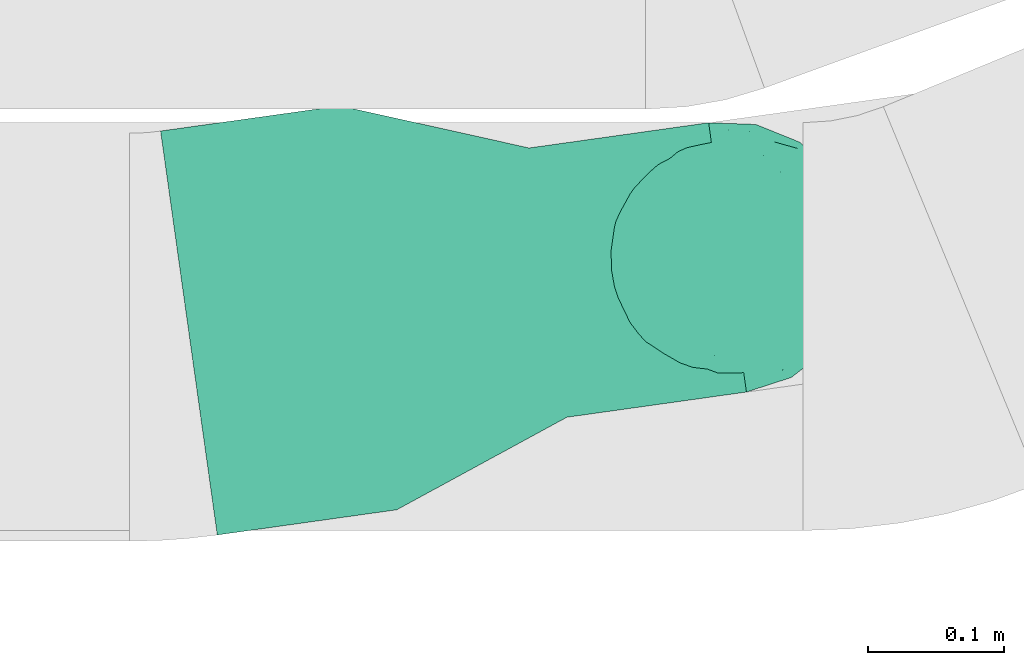
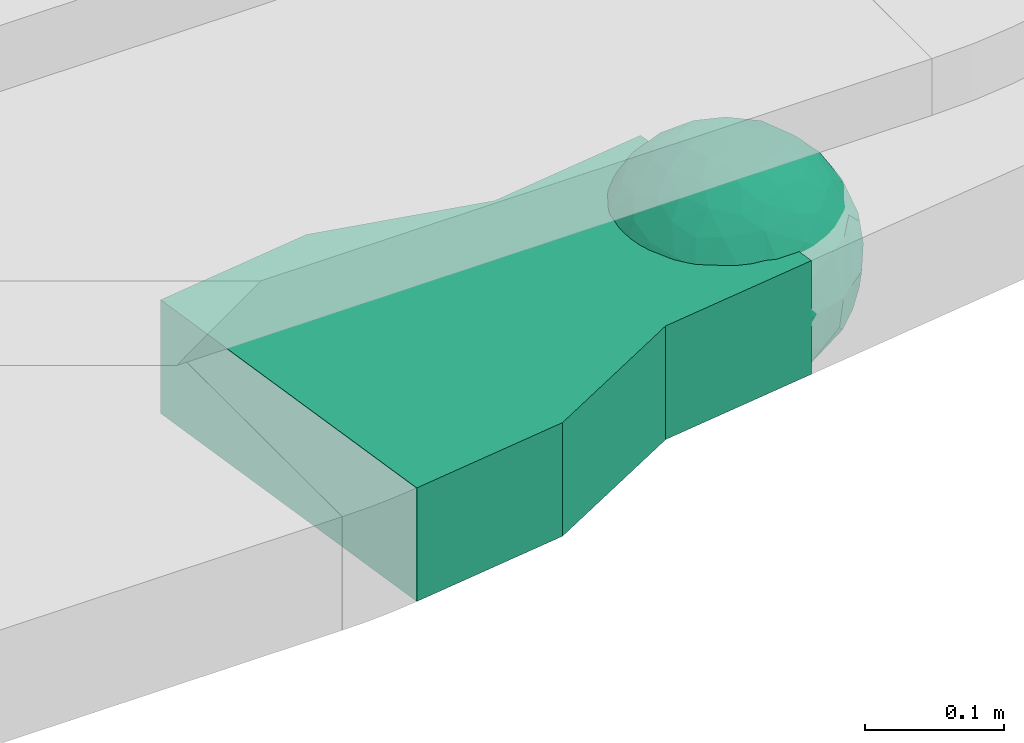
# One storey, part 30 of 32: 1 flow fitting.
"""IFC2X3 building model written with IfcOpenShell, lengths in millimetres."""

from ifc_helpers import new_model, entity, si_unit, converted_unit, derived_unit, direction, frame, origin, place, context, subcontext, project, spatial, faceted_brep, source, transform, mapped, material, material_list, type_object, type_shapes, element, save


model = new_model("IFC2X3")

# Units and contexts
model_context = context("Model", 3, precision=0.01, world=origin(), true_north=direction((6.12303176911189e-17, 1.0)))
body_context = subcontext(model_context, "Body", "Model", "MODEL_VIEW")
ifc_project = project(units=[si_unit("LENGTHUNIT", "METRE", prefix="MILLI"), si_unit("AREAUNIT", "SQUARE_METRE"), si_unit("VOLUMEUNIT", "CUBIC_METRE"), converted_unit("PLANEANGLEUNIT", "DEGREE", entity("IfcRatioMeasure", 0.0174532925199433), si_unit("PLANEANGLEUNIT", "RADIAN"), dimensions=[0, 0, 0, 0, 0, 0, 0]), si_unit("MASSUNIT", "GRAM", prefix="KILO"), derived_unit("MASSDENSITYUNIT", [(si_unit("MASSUNIT", "GRAM", prefix="KILO"), 1), (si_unit("LENGTHUNIT", "METRE"), -3)]), derived_unit("MOMENTOFINERTIAUNIT", [(si_unit("LENGTHUNIT", "METRE"), 4)]), si_unit("TIMEUNIT", "SECOND"), si_unit("FREQUENCYUNIT", "HERTZ"), si_unit("THERMODYNAMICTEMPERATUREUNIT", "DEGREE_CELSIUS"), derived_unit("THERMALTRANSMITTANCEUNIT", [(si_unit("MASSUNIT", "GRAM", prefix="KILO"), 1), (si_unit("THERMODYNAMICTEMPERATUREUNIT", "KELVIN"), -1), (si_unit("TIMEUNIT", "SECOND"), -3)]), derived_unit("VOLUMETRICFLOWRATEUNIT", [(si_unit("LENGTHUNIT", "METRE"), 3), (si_unit("TIMEUNIT", "SECOND"), -1)]), derived_unit("MASSFLOWRATEUNIT", [(si_unit("MASSUNIT", "GRAM", prefix="KILO"), 1), (si_unit("TIMEUNIT", "SECOND"), -1)]), derived_unit("ROTATIONALFREQUENCYUNIT", [(si_unit("TIMEUNIT", "SECOND"), -1)]), si_unit("ELECTRICCURRENTUNIT", "AMPERE"), si_unit("ELECTRICVOLTAGEUNIT", "VOLT"), si_unit("POWERUNIT", "WATT"), si_unit("FORCEUNIT", "NEWTON", prefix="KILO"), si_unit("ILLUMINANCEUNIT", "LUX"), si_unit("LUMINOUSFLUXUNIT", "LUMEN"), si_unit("LUMINOUSINTENSITYUNIT", "CANDELA"), derived_unit("USERDEFINED", [(si_unit("MASSUNIT", "GRAM", prefix="KILO"), -1), (si_unit("LENGTHUNIT", "METRE"), -2), (si_unit("TIMEUNIT", "SECOND"), 3), (si_unit("LUMINOUSFLUXUNIT", "LUMEN"), 1)]), derived_unit("LINEARVELOCITYUNIT", [(si_unit("LENGTHUNIT", "METRE"), 1), (si_unit("TIMEUNIT", "SECOND"), -1)]), si_unit("PRESSUREUNIT", "PASCAL"), derived_unit("USERDEFINED", [(si_unit("LENGTHUNIT", "METRE"), -2), (si_unit("MASSUNIT", "GRAM", prefix="KILO"), 1), (si_unit("TIMEUNIT", "SECOND"), -2)]), derived_unit("LINEARFORCEUNIT", [(si_unit("MASSUNIT", "GRAM", prefix="KILO"), 1), (si_unit("LENGTHUNIT", "METRE"), 1), (si_unit("TIMEUNIT", "SECOND"), -2), (si_unit("LENGTHUNIT", "METRE"), -1)]), derived_unit("PLANARFORCEUNIT", [(si_unit("MASSUNIT", "GRAM", prefix="KILO"), 1), (si_unit("LENGTHUNIT", "METRE"), 1), (si_unit("TIMEUNIT", "SECOND"), -2), (si_unit("LENGTHUNIT", "METRE"), -2)])], contexts=[model_context])

# Site, building, storey
site_placement = place(None, origin())
site = spatial("IfcSite", under=ifc_project, at=site_placement, CompositionType="ELEMENT")
building_placement = place(site_placement, origin())
building = spatial("IfcBuilding", under=site, at=building_placement, CompositionType="ELEMENT")
storey_placement = place(building_placement, frame((0.0, 0.0, 8100.0)))
storey = spatial("IfcBuildingStorey", under=building, at=storey_placement, CompositionType="ELEMENT", Elevation=8100.0)

# Flow fitting
ifc_material_1 = material()
ifc_material_2 = material()
ifc_material_list = material_list([ifc_material_1, ifc_material_2])
cable_carrier_fitting_type = type_object("IfcCableCarrierFittingType", Name="470_DKC_G5_Sheet reducer:-", PredefinedType="NOTDEFINED", material=ifc_material_1)
shared_shape = source(origin(), body_context, "Body", "Brep", [
    faceted_brep([(76.48, -37.8, -52.17), (89.29, -26.17, -36.65), (85.27, -46.63, -23.54), (-17.29, -34.78, -92.15), (0.0, -44.16, -89.72), (-24.64, -51.58, -82.05), (76.33, -15.08, -62.82), (55.58, -29.55, -77.71), (-17.1, 96.98, 0.0), (-18.67, 88.89, -41.84), (-33.9, 89.53, -28.9), (-45.46, -10.48, -88.45), (-19.82, 5.04, -97.89), (-23.66, -16.13, -95.81), (92.54, 33.68, 0.0), (85.28, 45.77, -25.16), (86.6, 50.0, 0.0), (49.24, -85.29, 0.0), (62.2, -72.19, -30.32), (64.28, -76.6, 0.0), (97.17, -8.72, -21.95), (90.76, 0.0, -41.98), (96.14, 14.4, -23.44), (98.48, 17.36, 0.0), (98.48, 0.0, 0.0), (79.01, 8.48, -60.71), (76.48, 37.8, -52.17), (87.7, 23.44, -41.95), (29.16, -37.6, -87.95), (20.3, -63.77, -74.31), (-69.62, 53.19, -48.2), (-47.21, 56.75, -67.46), (-61.6, 43.47, -65.69), (29.45, 71.32, -63.61), (47.21, 56.75, -67.46), (30.04, 49.65, -81.44), (-49.67, -77.09, -39.87), (-34.2, -93.97, 0.0), (-49.24, -85.29, 0.0), (61.4, 65.14, -44.57), (74.68, 59.14, -30.41), (61.95, 44.54, -64.64), (28.77, -89.42, -34.29), (34.2, -93.97, 0.0), (25.65, -95.48, 0.0), (17.1, -96.98, 0.0), (-64.28, -76.6, 0.0), (-75.44, -63.3, 0.0), (-74.75, -61.55, -24.99), (7.5, -83.69, -54.22), (36.49, -70.37, -60.97), (-76.48, -37.8, -52.17), (-87.07, -22.49, -43.74), (-79.06, -6.54, -60.88), (63.53, 0.0, -77.22), (-63.53, 0.0, -77.22), (-81.93, 16.04, -55.05), (-98.48, -17.36, 0.0), (-95.57, -17.05, -24.0), (-92.54, -33.68, 0.0), (65.86, 23.41, -71.51), (-19.3, 70.27, -68.49), (-44.33, 79.42, -41.56), (-76.48, 37.8, -52.17), (-45.05, 37.36, -81.09), (-67.2, 22.41, -70.59), (45.89, 15.54, -87.48), (-67.14, -22.46, -70.63), (-97.69, 5.09, -20.78), (-90.76, 0.0, -41.98), (-92.54, 33.68, 0.0), (-92.15, 27.2, -27.72), (28.87, 87.52, -38.83), (7.5, 83.69, -54.22), (1.23, 95.73, -28.9), (3.52, -95.84, -28.34), (-8.55, -98.49, 0.0), (-12.28, -96.15, -24.6), (75.44, 63.3, 0.0), (64.28, 76.6, 0.0), (75.44, -63.3, 0.0), (86.6, -50.0, 0.0), (-75.44, 63.3, 0.0), (-84.89, 46.81, -24.54), (-86.6, 50.0, 0.0), (-65.62, -61.39, -43.88), (-47.21, -56.75, -67.46), (-85.24, -44.68, -27.17), (46.02, 37.17, -80.63), (-63.18, 67.68, -37.79), (-7.15, -67.62, -73.33), (31.54, -5.3, -94.75), (9.85, -20.5, -97.38), (0.0, 13.3, -99.11), (49.35, -11.18, -86.25), (92.54, -33.68, 0.0), (98.48, -17.36, 0.0), (49.24, 85.29, 0.0), (46.4, 79.11, -39.86), (34.2, 93.97, 0.0), (-53.11, 15.12, -83.37), (64.53, -54.17, -53.86), (47.21, -56.75, -67.46), (22.89, 27.57, -93.36), (74.68, -59.14, -30.41), (46.4, -79.11, -39.86), (-15.74, 23.19, -95.99), (2.81, 33.98, -94.01), (9.21, 52.39, -84.68), (9.73, 69.75, -71.0), (17.1, 96.98, 0.0), (-5.62, -90.16, -42.88), (0.0, -100.0, 0.0), (-25.13, -93.37, -25.51), (-25.95, -84.88, -46.06), (-17.1, -96.98, 0.0), (-10.24, -80.78, -58.05), (-31.24, -69.76, -64.48), (-42.19, -33.64, -84.2), (-35.78, 18.55, -91.52), (-61.62, -43.52, -65.64), (-17.34, 40.89, -89.6), (-29.1, 55.69, -77.79), (-10.66, 57.03, -81.45), (-59.77, -75.57, -26.75), (-86.6, -50.0, 0.0), (-98.48, 0.0, 0.0), (-98.48, 17.36, 0.0), (-74.77, 60.7, -26.92), (-64.28, 76.6, 0.0), (-49.24, 85.29, 0.0), (-34.2, 93.97, 0.0), (0.0, 100.0, 0.0), (-76.48, -37.8, 52.17), (-89.29, -26.17, 36.65), (-85.27, -46.63, 23.54), (17.29, -34.78, 92.15), (0.0, -44.16, 89.72), (24.64, -51.58, 82.05), (-76.33, -15.08, 62.82), (-55.58, -29.55, 77.71), (18.67, 88.89, 41.84), (33.9, 89.53, 28.9), (17.34, 40.89, 89.6), (15.74, 23.19, 95.99), (35.78, 18.55, 91.52), (-85.28, 45.77, 25.16), (-62.2, -72.19, 30.32), (-97.17, -8.72, 21.95), (-96.14, 14.4, 23.44), (-79.01, 8.48, 60.71), (-76.48, 37.8, 52.17), (-87.7, 23.44, 41.95), (-29.16, -37.6, 87.95), (-20.3, -63.77, 74.31), (69.62, 53.19, 48.2), (47.21, 56.75, 67.46), (61.6, 43.47, 65.69), (-61.4, 65.14, 44.57), (49.27, -77.35, 39.88), (-74.68, 59.14, 30.41), (-61.95, 44.54, 64.64), (-7.5, -83.69, 54.22), (-36.49, -70.37, 60.97), (-28.77, -89.42, 34.29), (74.74, -61.65, 24.74), (3.0, -95.52, 29.45), (-13.47, -92.75, 34.88), (76.48, -37.8, 52.17), (87.07, -22.49, 43.74), (79.06, -6.54, 60.88), (-63.53, 0.0, 77.22), (63.53, 0.0, 77.22), (81.93, 16.04, 55.05), (95.57, -17.05, 24.0), (-65.86, 23.41, 71.51), (19.3, 70.27, 68.49), (44.33, 79.42, 41.56), (76.48, 37.8, 52.17), (45.05, 37.36, 81.09), (67.2, 22.41, 70.59), (-45.89, 15.54, 87.48), (67.14, -22.46, 70.63), (97.69, 5.09, 20.78), (90.76, 0.0, 41.98), (92.15, 27.2, 27.72), (-28.87, 87.52, 38.83), (-7.5, 83.69, 54.22), (-1.23, 95.73, 28.9), (7.15, -67.62, 73.33), (30.04, -71.02, 63.66), (-90.76, 0.0, 41.98), (84.89, 46.81, 24.54), (65.66, -61.85, 43.17), (47.21, -56.75, 67.46), (85.24, -44.68, 27.17), (-30.04, 49.65, 81.44), (-47.21, 56.75, 67.46), (-46.02, 37.17, 80.63), (63.18, 67.68, 37.79), (-31.54, -5.3, 94.75), (-9.85, -20.5, 97.38), (0.0, 13.3, 99.11), (-49.35, -11.18, 86.25), (-46.4, 79.11, 39.86), (-29.45, 71.32, 63.61), (24.31, -93.79, 24.74), (-64.53, -54.17, 53.86), (-47.21, -56.75, 67.46), (-22.89, 27.57, 93.36), (-46.4, -79.11, 39.86), (-74.68, -59.14, 30.41), (19.82, 5.04, 97.89), (-2.81, 33.98, 94.01), (-9.21, 52.39, 84.68), (-9.73, 69.75, 71.0), (9.65, -80.54, 58.49), (23.47, -86.31, 44.72), (35.11, -89.62, 27.11), (42.19, -33.64, 84.2), (23.66, -16.13, 95.81), (45.46, -10.48, 88.45), (61.62, -43.52, 65.64), (29.1, 55.69, 77.79), (10.66, 57.03, 81.45), (59.35, -75.82, 26.99), (74.77, 60.7, 26.92), (53.11, 15.12, 83.37)], [[[0, 1, 2]], [[3, 4, 5]], [[6, 0, 7]], [[8, 9, 10]], [[11, 12, 13]], [[14, 15, 16]], [[17, 18, 19]], [[20, 21, 22]], [[22, 23, 24]], [[25, 26, 27]], [[4, 28, 29]], [[30, 31, 32]], [[33, 34, 35]], [[36, 37, 38]], [[39, 40, 41]], [[42, 43, 44, 45]], [[46, 47, 48]], [[49, 50, 42]], [[51, 52, 53]], [[54, 25, 6]], [[55, 53, 56]], [[57, 58, 59]], [[26, 25, 60]], [[61, 31, 62]], [[32, 63, 30]], [[64, 65, 32]], [[54, 66, 60]], [[53, 67, 51]], [[58, 68, 69]], [[68, 70, 71]], [[72, 73, 74]], [[75, 76, 77]], [[6, 7, 54]], [[24, 20, 22]], [[78, 40, 79]], [[15, 26, 40]], [[1, 21, 20]], [[80, 2, 81]], [[63, 56, 71]], [[82, 83, 84]], [[36, 85, 86]], [[87, 58, 52]], [[35, 34, 88]], [[62, 31, 89]], [[42, 75, 49]], [[4, 29, 90]], [[91, 92, 93]], [[7, 94, 54]], [[6, 1, 0]], [[95, 81, 2]], [[24, 96, 20]], [[1, 20, 95]], [[1, 95, 2]], [[27, 22, 21]], [[15, 14, 22]], [[25, 27, 21]], [[15, 78, 16]], [[41, 40, 26]], [[40, 78, 15]], [[39, 97, 79]], [[97, 98, 99]], [[40, 39, 79]], [[33, 73, 72]], [[21, 1, 6]], [[25, 54, 60]], [[64, 100, 65]], [[26, 15, 27]], [[6, 25, 21]], [[0, 101, 7]], [[102, 28, 7]], [[92, 91, 28]], [[94, 28, 91]], [[88, 34, 41]], [[54, 94, 66]], [[41, 26, 60]], [[103, 91, 93]], [[88, 41, 60]], [[20, 96, 95]], [[101, 18, 102]], [[104, 80, 19]], [[101, 0, 104]], [[18, 105, 102]], [[43, 42, 105]], [[17, 43, 105]], [[29, 28, 102]], [[28, 4, 92]], [[105, 50, 102]], [[90, 29, 49]], [[88, 60, 66]], [[41, 34, 39]], [[34, 98, 39]], [[97, 39, 98]], [[103, 66, 91]], [[88, 66, 103]], [[12, 106, 93]], [[33, 98, 34]], [[107, 103, 93]], [[35, 103, 108]], [[103, 35, 88]], [[33, 109, 73]], [[109, 35, 108]], [[110, 72, 74]], [[72, 110, 99]], [[98, 33, 72]], [[99, 98, 72]], [[80, 104, 2]], [[0, 2, 104]], [[101, 104, 18]], [[7, 101, 102]], [[19, 18, 104]], [[105, 18, 17]], [[77, 111, 75]], [[75, 45, 112]], [[113, 114, 111]], [[115, 77, 76]], [[36, 114, 37]], [[90, 5, 4]], [[75, 42, 45]], [[50, 49, 29]], [[49, 116, 90]], [[5, 117, 86]], [[90, 116, 117]], [[118, 13, 3]], [[118, 5, 86]], [[11, 119, 12]], [[67, 120, 51]], [[11, 13, 118]], [[65, 55, 56]], [[121, 122, 123]], [[90, 117, 5]], [[51, 120, 85]], [[117, 36, 86]], [[36, 117, 114]], [[46, 48, 124]], [[38, 124, 36]], [[85, 124, 48]], [[87, 125, 59]], [[125, 87, 47]], [[48, 51, 85]], [[68, 57, 126, 127]], [[59, 58, 87]], [[58, 69, 52]], [[53, 52, 69]], [[87, 52, 51]], [[56, 53, 69]], [[53, 55, 67]], [[71, 56, 69]], [[56, 63, 65]], [[71, 69, 68]], [[128, 129, 89]], [[11, 67, 55]], [[120, 118, 86]], [[32, 65, 63]], [[100, 55, 65]], [[118, 120, 67]], [[85, 120, 86]], [[129, 128, 82]], [[64, 32, 31]], [[62, 130, 131]], [[130, 62, 89]], [[9, 73, 61]], [[10, 62, 131]], [[109, 61, 73]], [[73, 9, 74]], [[64, 121, 119]], [[122, 61, 123]], [[64, 119, 100]], [[64, 31, 122]], [[107, 108, 103]], [[47, 87, 48]], [[51, 48, 87]], [[57, 68, 58]], [[64, 122, 121]], [[89, 129, 130]], [[67, 11, 118]], [[11, 55, 100]], [[82, 128, 83]], [[30, 128, 89]], [[83, 63, 71]], [[63, 83, 128]], [[84, 83, 71]], [[10, 61, 62]], [[74, 8, 132]], [[8, 74, 9]], [[110, 74, 132]], [[3, 92, 4]], [[92, 13, 12]], [[22, 27, 15]], [[14, 23, 22]], [[11, 100, 119]], [[128, 30, 63]], [[31, 30, 89]], [[28, 94, 7]], [[66, 94, 91]], [[42, 50, 105]], [[29, 102, 50]], [[106, 107, 93]], [[123, 107, 121]], [[35, 109, 33]], [[109, 108, 123]], [[75, 112, 76]], [[113, 77, 115]], [[114, 116, 111]], [[115, 37, 113]], [[37, 114, 113]], [[49, 75, 111]], [[117, 116, 114]], [[111, 77, 113]], [[49, 111, 116]], [[118, 3, 5]], [[92, 3, 13]], [[106, 119, 121]], [[92, 12, 93]], [[119, 106, 12]], [[107, 106, 121]], [[46, 124, 38]], [[85, 36, 124]], [[70, 68, 127]], [[70, 84, 71]], [[31, 61, 122]], [[109, 123, 61]], [[107, 123, 108]], [[8, 10, 131]], [[61, 10, 9]], [[133, 134, 135]], [[136, 137, 138]], [[139, 133, 140]], [[110, 141, 142]], [[143, 144, 145]], [[70, 146, 84]], [[38, 147, 46]], [[126, 57, 148]], [[149, 127, 126]], [[150, 151, 152]], [[137, 153, 154]], [[155, 156, 157]], [[130, 129, 158]], [[159, 43, 17]], [[158, 160, 161]], [[162, 163, 164]], [[19, 80, 165]], [[166, 167, 115]], [[168, 169, 170]], [[171, 150, 139]], [[172, 170, 173]], [[96, 174, 95]], [[151, 150, 175]], [[176, 156, 177]], [[157, 178, 155]], [[179, 180, 157]], [[171, 181, 175]], [[170, 182, 168]], [[174, 183, 184]], [[185, 23, 14, 16]], [[186, 187, 188]], [[138, 189, 190]], [[139, 140, 171]], [[126, 148, 149]], [[82, 160, 129]], [[146, 151, 160]], [[134, 191, 148]], [[47, 135, 125]], [[178, 173, 185]], [[78, 192, 16]], [[159, 193, 194]], [[195, 174, 169]], [[196, 197, 198]], [[177, 156, 199]], [[166, 112, 45]], [[154, 189, 137]], [[200, 201, 202]], [[140, 203, 171]], [[191, 149, 148]], [[59, 125, 135]], [[133, 139, 134]], [[134, 148, 59]], [[134, 59, 135]], [[152, 149, 191]], [[146, 70, 149]], [[150, 152, 191]], [[146, 82, 84]], [[161, 160, 151]], [[160, 82, 146]], [[204, 131, 130]], [[186, 205, 187]], [[160, 158, 129]], [[197, 196, 205]], [[191, 134, 139]], [[150, 171, 175]], [[45, 206, 166]], [[151, 146, 152]], [[139, 150, 191]], [[133, 207, 140]], [[208, 153, 140]], [[201, 200, 153]], [[203, 153, 200]], [[198, 197, 161]], [[171, 203, 181]], [[161, 151, 175]], [[209, 200, 202]], [[198, 161, 175]], [[148, 57, 59]], [[38, 37, 210]], [[211, 47, 46]], [[207, 133, 211]], [[147, 210, 208]], [[210, 37, 164]], [[208, 207, 147]], [[154, 153, 208]], [[153, 137, 201]], [[210, 163, 208]], [[189, 154, 162]], [[198, 175, 181]], [[161, 197, 158]], [[197, 204, 158]], [[130, 158, 204]], [[209, 181, 200]], [[198, 181, 209]], [[212, 144, 202]], [[205, 204, 197]], [[213, 209, 202]], [[196, 209, 214]], [[209, 196, 198]], [[205, 215, 187]], [[215, 196, 214]], [[8, 186, 188]], [[186, 8, 131]], [[204, 205, 186]], [[131, 204, 186]], [[47, 211, 135]], [[133, 135, 211]], [[207, 211, 147]], [[140, 207, 208]], [[46, 147, 211]], [[210, 147, 38]], [[166, 115, 76, 112]], [[115, 164, 37]], [[163, 162, 154]], [[216, 166, 217]], [[138, 137, 189]], [[162, 216, 189]], [[218, 44, 43]], [[44, 218, 206]], [[189, 216, 190]], [[219, 220, 136]], [[219, 138, 194]], [[221, 145, 212]], [[182, 222, 168]], [[221, 220, 219]], [[180, 172, 173]], [[143, 223, 224]], [[168, 222, 193]], [[194, 138, 190]], [[190, 159, 194]], [[190, 217, 218]], [[19, 165, 225]], [[17, 225, 159]], [[193, 225, 165]], [[195, 81, 95]], [[81, 195, 80]], [[165, 168, 193]], [[183, 96, 24, 23]], [[95, 174, 195]], [[174, 184, 169]], [[170, 169, 184]], [[195, 169, 168]], [[173, 170, 184]], [[170, 172, 182]], [[185, 173, 184]], [[173, 178, 180]], [[185, 184, 183]], [[226, 79, 199]], [[221, 182, 172]], [[222, 219, 194]], [[157, 180, 178]], [[227, 172, 180]], [[219, 222, 182]], [[193, 222, 194]], [[79, 226, 78]], [[179, 157, 156]], [[177, 97, 99]], [[97, 177, 199]], [[141, 187, 176]], [[142, 177, 99]], [[215, 176, 187]], [[187, 141, 188]], [[179, 143, 145]], [[223, 176, 224]], [[179, 145, 227]], [[179, 156, 223]], [[213, 214, 209]], [[96, 183, 174]], [[185, 183, 23]], [[80, 195, 165]], [[168, 165, 195]], [[199, 79, 97]], [[182, 221, 219]], [[221, 172, 227]], [[78, 226, 192]], [[155, 226, 199]], [[192, 178, 185]], [[178, 192, 226]], [[16, 192, 185]], [[142, 176, 177]], [[188, 110, 132]], [[110, 188, 141]], [[8, 188, 132]], [[136, 201, 137]], [[201, 220, 212]], [[149, 152, 146]], [[70, 127, 149]], [[167, 162, 164]], [[179, 227, 180]], [[221, 227, 145]], [[226, 155, 178]], [[156, 155, 199]], [[153, 203, 140]], [[181, 203, 200]], [[164, 163, 210]], [[154, 208, 163]], [[144, 213, 202]], [[224, 213, 143]], [[196, 215, 205]], [[215, 214, 224]], [[166, 216, 162]], [[190, 216, 217]], [[218, 217, 206]], [[43, 159, 218]], [[190, 218, 159]], [[166, 206, 217]], [[44, 206, 45]], [[219, 136, 138]], [[201, 136, 220]], [[201, 212, 202]], [[221, 212, 220]], [[145, 144, 212]], [[213, 144, 143]], [[19, 225, 17]], [[193, 159, 225]], [[179, 223, 143]], [[156, 176, 223]], [[215, 224, 176]], [[213, 224, 214]], [[110, 142, 99]], [[176, 142, 141]], [[115, 167, 164]], [[166, 162, 167]]]),
    faceted_brep([(0.0, 100.0, 50.0), (0.0, 100.0, -50.0), (0.0, -100.0, -50.0), (0.0, -100.0, 50.0), (133.33, 100.0, 50.0), (133.33, 100.0, -50.0), (266.67, 150.0, -50.0), (400.0, 150.0, -50.0), (400.0, -150.0, -50.0), (266.67, -150.0, -50.0), (133.33, -100.0, -50.0), (133.33, -100.0, 50.0), (266.67, -150.0, 50.0), (400.0, -150.0, 50.0), (400.0, 150.0, 50.0), (266.67, 150.0, 50.0)], [[[0, 1, 2, 3]], [[1, 0, 4, 5]], [[2, 1, 5, 6, 7, 8, 9, 10]], [[3, 2, 10, 11]], [[0, 3, 11, 12, 13, 14, 15, 4]], [[12, 11, 10, 9]], [[4, 15, 6, 5]], [[14, 13, 8, 7]], [[14, 7, 6, 15]], [[8, 13, 12, 9]]]),
])
type_shapes(cable_carrier_fitting_type, [shared_shape])
flow_fitting_placement = place(storey_placement, frame((27011.9, 14383.15, 2615.0), z_axis=(4.34556869807782e-07, 6.09975744374032e-08, 1.0), x_axis=(-0.990291738562734, -0.139004577385798, 4.388170201626e-07)))
element("IfcFlowFitting", 1, at=flow_fitting_placement, inside=storey, type_object=cable_carrier_fitting_type, material=ifc_material_list, Name="470_DKC_G5_Sheet reducer:-", ObjectType="470_DKC_G5_Sheet reducer:-", context=body_context, shape_type="MappedRepresentation", body=[
    mapped(shared_shape, transform((0.0, 0.0, 0.0), scale=1.0)),
])

save(model, "model.ifc")
